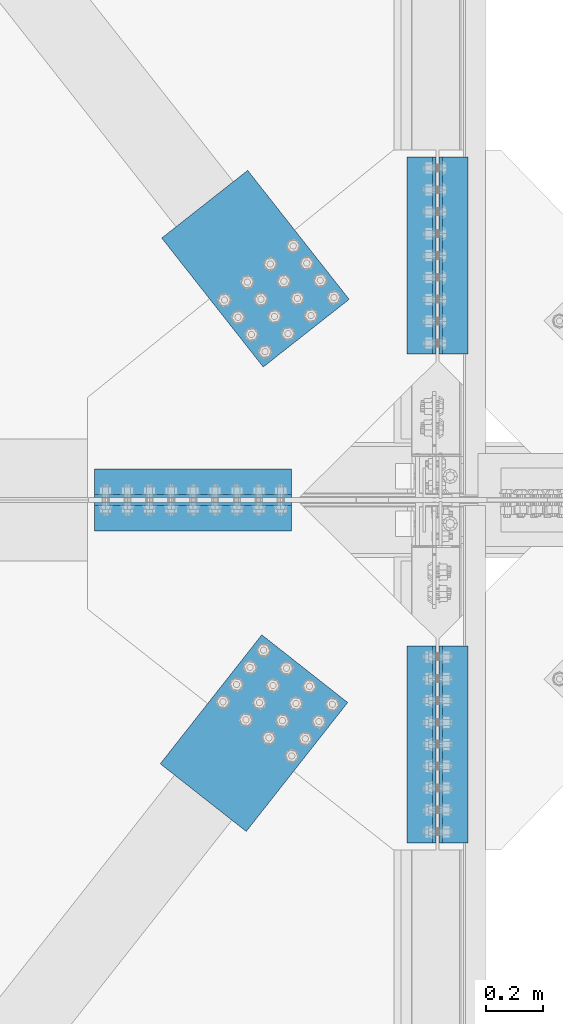
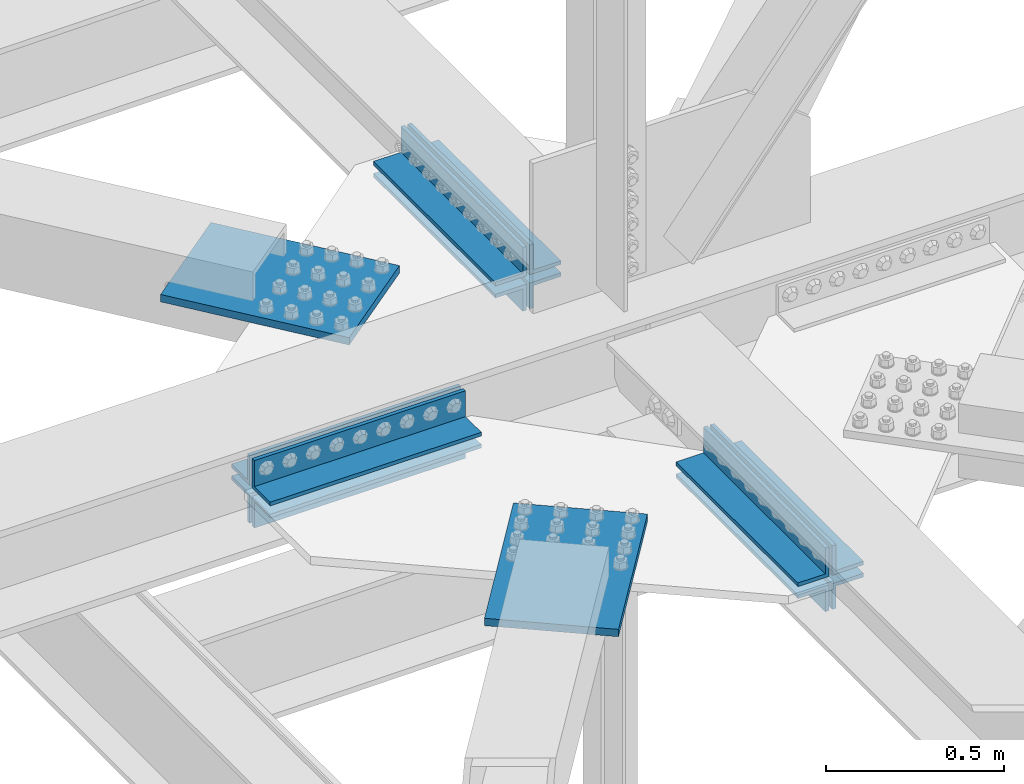
# One storey, part 2360 of 3843: 14 beams, 6 elements without a shape of their own.
"""IFC2X3 building model written with IfcOpenShell, lengths in millimetres."""

from ifc_helpers import new_model, si_unit, frame, origin_with_axes, place, context, subcontext, project, spatial, faceted_brep, material, type_object, element, aggregate, save


model = new_model("IFC2X3")

# Units and contexts
model_context = context("Model", 3, precision=1e-05, world=origin_with_axes())
body_context = subcontext(model_context, "Body", "Model", "MODEL_VIEW")
ifc_project = project(units=[si_unit("LENGTHUNIT", "METRE", prefix="MILLI"), si_unit("AREAUNIT", "SQUARE_METRE"), si_unit("VOLUMEUNIT", "CUBIC_METRE"), si_unit("MASSUNIT", "GRAM", prefix="KILO"), si_unit("TIMEUNIT", "SECOND"), si_unit("PLANEANGLEUNIT", "RADIAN"), si_unit("SOLIDANGLEUNIT", "STERADIAN"), si_unit("THERMODYNAMICTEMPERATUREUNIT", "DEGREE_CELSIUS"), si_unit("LUMINOUSINTENSITYUNIT", "LUMEN")], contexts=[model_context])

# Site, building, storey
site_placement = place(None, origin_with_axes())
site = spatial("IfcSite", under=ifc_project, at=site_placement, CompositionType="ELEMENT")
building_placement = place(site_placement, origin_with_axes())
building = spatial("IfcBuilding", under=site, at=building_placement, Name="Undefined", CompositionType="ELEMENT")
storey_placement = place(building_placement, origin_with_axes())
storey = spatial("IfcBuildingStorey", under=building, at=storey_placement, Name="Undefined", CompositionType="ELEMENT", Elevation=0.0)

# Assembly, beam
assembly_1_placement = place(storey_placement, origin_with_axes())
assembly_1 = element("IfcElementAssembly", 1, at=assembly_1_placement, inside=storey, Name="PLATE", AssemblyPlace="NOTDEFINED", PredefinedType="RIGID_FRAME")
ifc_material = material(Name="STEEL/A572-50")
beam_type_1 = type_object("IfcBeamType", Name="L4X4X1/2", PredefinedType="NOTDEFINED")
beam_1_placement = place(assembly_1_placement, frame((76504.8000192098, 58973.2439848795, 42167.1749999991), z_axis=(0.0, 1.0, 0.0), x_axis=(-1.0, 0.0, 0.0)))
beam_1 = element("IfcBeam", 2, at=beam_1_placement, type_object=beam_type_1, material=ifc_material, Name="ANGLE", ObjectType="L4X4X1/2", context=body_context, shape_type="Brep", body=[
    faceted_brep([(0.0, 50.8000000000029, -50.8000000000029), (0.0, 50.8000000000029, 50.8000000000029), (685.800000000003, 50.8000000000029, 50.8000000000029), (685.800000000003, 50.8000000000029, -50.8000000000029), (0.0, 38.0999999999985, 50.8000000000029), (685.800000000003, 38.0999999999985, 50.8000000000029), (0.0, 38.0999999999985, -38.0999999999985), (685.800000000003, 38.0999999999985, -38.1000000000058), (0.0, -50.8000000000029, -38.1000000000058), (685.800000000003, -50.8000000000029, -38.1000000000058), (0.0, -50.8000000000029, -50.8000000000029), (685.800000000003, -50.8000000000029, -50.8000000000029)], [[[0, 1, 2, 3]], [[1, 4, 5, 2]], [[4, 6, 7, 5]], [[6, 8, 9, 7]], [[8, 10, 11, 9]], [[10, 0, 3, 11]], [[5, 7, 9, 11, 3, 2]], [[10, 8, 6, 4, 1, 0]]]),
])

assembly_2_placement = place(storey_placement, origin_with_axes())
assembly_2 = element("IfcElementAssembly", 3, at=assembly_2_placement, inside=storey, Name="PLATE", AssemblyPlace="NOTDEFINED", PredefinedType="RIGID_FRAME")
beam_2_placement = place(assembly_2_placement, frame((75819.0000192098, 58857.356234873, 42167.1744995137), z_axis=(0.0, -1.0, 0.0), x_axis=(1.0, 0.0, 0.0)))
beam_2 = element("IfcBeam", 4, at=beam_2_placement, type_object=beam_type_1, material=ifc_material, Name="ANGLE", ObjectType="L4X4X1/2", context=body_context, shape_type="Brep", body=[
    faceted_brep([(0.0, 50.8000000000029, -50.8000000000029), (0.0, 50.8000000000029, 50.8000000000029), (685.800000000003, 50.8000000000029, 50.8000000000029), (685.800000000003, 50.8000000000029, -50.8000000000029), (0.0, 38.0999999999985, 50.8000000000029), (685.800000000003, 38.0999999999985, 50.8000000000029), (0.0, 38.0999999999985, -38.0999999999985), (685.800000000003, 38.0999999999985, -38.1000000000058), (0.0, -50.8000000000029, -38.1000000000058), (685.800000000003, -50.8000000000029, -38.1000000000058), (0.0, -50.8000000000029, -50.8000000000029), (685.800000000003, -50.8000000000029, -50.8000000000029)], [[[0, 1, 2, 3]], [[1, 4, 5, 2]], [[4, 6, 7, 5]], [[6, 8, 9, 7]], [[8, 10, 11, 9]], [[10, 0, 3, 11]], [[5, 7, 9, 11, 3, 2]], [[10, 8, 6, 4, 1, 0]]]),
])

assembly_3_placement = place(storey_placement, origin_with_axes())
assembly_3 = element("IfcElementAssembly", 5, at=assembly_3_placement, inside=storey, Name="PLATE", AssemblyPlace="NOTDEFINED", PredefinedType="RIGID_FRAME")
beam_3_placement = place(assembly_3_placement, frame((77068.3625222877, 60109.0999848818, 42297.3495002747), z_axis=(1.0, 0.0, 0.0), x_axis=(0.0, -1.0, 0.0)))
beam_3 = element("IfcBeam", 6, at=beam_3_placement, type_object=beam_type_1, material=ifc_material, Name="ANGLE", ObjectType="L4X4X1/2", context=body_context, shape_type="Brep", body=[
    faceted_brep([(0.0, 50.8000000000029, -50.8000000000029), (0.0, 50.8000000000029, 50.8000000000029), (685.800000000003, 50.8000000000029, 50.8000000000029), (685.800000000003, 50.8000000000029, -50.8000000000029), (0.0, 38.0999999999985, 50.8000000000029), (685.800000000003, 38.0999999999985, 50.8000000000029), (0.0, 38.0999999999985, -38.0999999999985), (685.800000000003, 38.0999999999985, -38.1000000000058), (0.0, -50.8000000000029, -38.1000000000058), (685.800000000003, -50.8000000000029, -38.1000000000058), (0.0, -50.8000000000029, -50.8000000000029), (685.800000000003, -50.8000000000029, -50.8000000000029)], [[[0, 1, 2, 3]], [[1, 4, 5, 2]], [[4, 6, 7, 5]], [[6, 8, 9, 7]], [[8, 10, 11, 9]], [[10, 0, 3, 11]], [[5, 7, 9, 11, 3, 2]], [[10, 8, 6, 4, 1, 0]]]),
])

assembly_4_placement = place(storey_placement, origin_with_axes())
assembly_4 = element("IfcElementAssembly", 7, at=assembly_4_placement, inside=storey, Name="PLATE", AssemblyPlace="NOTDEFINED", PredefinedType="RIGID_FRAME")
beam_4_placement = place(assembly_4_placement, frame((77068.362519207, 58407.2999848772, 42297.3495002747), z_axis=(1.0, 0.0, 0.0), x_axis=(0.0, -1.0, 0.0)))
beam_4 = element("IfcBeam", 8, at=beam_4_placement, type_object=beam_type_1, material=ifc_material, Name="ANGLE", ObjectType="L4X4X1/2", context=body_context, shape_type="Brep", body=[
    faceted_brep([(0.0, 50.8000000000029, -50.8000000000029), (0.0, 50.8000000000029, 50.8000000000029), (685.800000000003, 50.8000000000029, 50.8000000000029), (685.800000000003, 50.8000000000029, -50.8000000000029), (0.0, 38.0999999999985, 50.8000000000029), (685.800000000003, 38.0999999999985, 50.8000000000029), (0.0, 38.0999999999985, -38.0999999999985), (685.800000000003, 38.0999999999985, -38.1000000000058), (0.0, -50.8000000000029, -38.1000000000058), (685.800000000003, -50.8000000000029, -38.1000000000058), (0.0, -50.8000000000029, -50.8000000000029), (685.800000000003, -50.8000000000029, -50.8000000000029)], [[[0, 1, 2, 3]], [[1, 4, 5, 2]], [[4, 6, 7, 5]], [[6, 8, 9, 7]], [[8, 10, 11, 9]], [[10, 0, 3, 11]], [[5, 7, 9, 11, 3, 2]], [[10, 8, 6, 4, 1, 0]]]),
])

# Beam
beam_5_placement = place(assembly_1_placement, frame((75819.000019208, 58973.2437348795, 42297.3495002747), z_axis=(0.0, 1.0, 0.0), x_axis=(1.0, 0.0, 0.0)))
beam_5 = element("IfcBeam", 9, at=beam_5_placement, type_object=beam_type_1, material=ifc_material, Name="ANGLE", ObjectType="L4X4X1/2", context=body_context, shape_type="Brep", body=[
    faceted_brep([(0.0, 50.8000000000029, -50.8000000000029), (0.0, 50.8000000000029, 50.8000000000029), (685.800000000003, 50.8000000000029, 50.8000000000029), (685.800000000003, 50.8000000000029, -50.8000000000029), (0.0, 38.0999999999985, 50.8000000000029), (685.800000000003, 38.0999999999985, 50.8000000000029), (0.0, 38.0999999999985, -38.0999999999985), (685.800000000003, 38.0999999999985, -38.1000000000058), (0.0, -50.8000000000029, -38.1000000000058), (685.800000000003, -50.8000000000029, -38.1000000000058), (0.0, -50.8000000000029, -50.8000000000029), (685.800000000003, -50.8000000000029, -50.8000000000029)], [[[0, 1, 2, 3]], [[1, 4, 5, 2]], [[4, 6, 7, 5]], [[6, 8, 9, 7]], [[8, 10, 11, 9]], [[10, 0, 3, 11]], [[5, 7, 9, 11, 3, 2]], [[10, 8, 6, 4, 1, 0]]]),
])

beam_6_placement = place(assembly_1_placement, frame((76957.2375222877, 59423.2999848818, 42297.3495002747), z_axis=(-1.0, 0.0, 0.0), x_axis=(0.0, 1.0, 0.0)))
beam_6 = element("IfcBeam", 10, at=beam_6_placement, type_object=beam_type_1, material=ifc_material, Name="ANGLE", ObjectType="L4X4X1/2", context=body_context, shape_type="Brep", body=[
    faceted_brep([(0.0, 50.8000000000029, -50.8000000000029), (0.0, 50.8000000000029, 50.8000000000029), (685.800000000003, 50.8000000000029, 50.8000000000029), (685.800000000003, 50.8000000000029, -50.8000000000029), (0.0, 38.0999999999985, 50.8000000000029), (685.800000000003, 38.0999999999985, 50.8000000000029), (0.0, 38.0999999999985, -38.0999999999985), (685.800000000003, 38.0999999999985, -38.1000000000058), (0.0, -50.8000000000029, -38.1000000000058), (685.800000000003, -50.8000000000029, -38.1000000000058), (0.0, -50.8000000000029, -50.8000000000029), (685.800000000003, -50.8000000000029, -50.8000000000029)], [[[0, 1, 2, 3]], [[1, 4, 5, 2]], [[4, 6, 7, 5]], [[6, 8, 9, 7]], [[8, 10, 11, 9]], [[10, 0, 3, 11]], [[5, 7, 9, 11, 3, 2]], [[10, 8, 6, 4, 1, 0]]]),
])

beam_7_placement = place(assembly_2_placement, frame((76504.800019208, 58857.3562348795, 42297.3495002747), z_axis=(0.0, -1.0, 0.0), x_axis=(-1.0, 0.0, 0.0)))
beam_7 = element("IfcBeam", 11, at=beam_7_placement, type_object=beam_type_1, material=ifc_material, Name="ANGLE", ObjectType="L4X4X1/2", context=body_context, shape_type="Brep", body=[
    faceted_brep([(0.0, 50.8000000000029, -50.8000000000029), (0.0, 50.8000000000029, 50.8000000000029), (685.800000000003, 50.8000000000029, 50.8000000000029), (685.800000000003, 50.8000000000029, -50.8000000000029), (0.0, 38.0999999999985, 50.8000000000029), (685.800000000003, 38.0999999999985, 50.8000000000029), (0.0, 38.0999999999985, -38.0999999999985), (685.800000000003, 38.0999999999985, -38.1000000000058), (0.0, -50.8000000000029, -38.1000000000058), (685.800000000003, -50.8000000000029, -38.1000000000058), (0.0, -50.8000000000029, -50.8000000000029), (685.800000000003, -50.8000000000029, -50.8000000000029)], [[[0, 1, 2, 3]], [[1, 4, 5, 2]], [[4, 6, 7, 5]], [[6, 8, 9, 7]], [[8, 10, 11, 9]], [[10, 0, 3, 11]], [[5, 7, 9, 11, 3, 2]], [[10, 8, 6, 4, 1, 0]]]),
])

beam_8_placement = place(assembly_2_placement, frame((76957.237519207, 57721.4999848772, 42297.3495002747), z_axis=(-1.0, 0.0, 0.0), x_axis=(0.0, 1.0, 0.0)))
beam_8 = element("IfcBeam", 12, at=beam_8_placement, type_object=beam_type_1, material=ifc_material, Name="ANGLE", ObjectType="L4X4X1/2", context=body_context, shape_type="Brep", body=[
    faceted_brep([(0.0, 50.8000000000029, -50.8000000000029), (0.0, 50.8000000000029, 50.8000000000029), (685.800000000003, 50.8000000000029, 50.8000000000029), (685.800000000003, 50.8000000000029, -50.8000000000029), (0.0, 38.0999999999985, 50.8000000000029), (685.800000000003, 38.0999999999985, 50.8000000000029), (0.0, 38.0999999999985, -38.0999999999985), (685.800000000003, 38.0999999999985, -38.1000000000058), (0.0, -50.8000000000029, -38.1000000000058), (685.800000000003, -50.8000000000029, -38.1000000000058), (0.0, -50.8000000000029, -50.8000000000029), (685.800000000003, -50.8000000000029, -50.8000000000029)], [[[0, 1, 2, 3]], [[1, 4, 5, 2]], [[4, 6, 7, 5]], [[6, 8, 9, 7]], [[8, 10, 11, 9]], [[10, 0, 3, 11]], [[5, 7, 9, 11, 3, 2]], [[10, 8, 6, 4, 1, 0]]]),
])

beam_type_2 = type_object("IfcBeamType", Name="L4X3-1/2X1/2", PredefinedType="NOTDEFINED")
beam_9_placement = place(assembly_3_placement, frame((77068.3625222877, 59423.2999848818, 42173.5244995117), z_axis=(1.0, 0.0, 0.0), x_axis=(0.0, 1.0, 0.0)))
beam_9 = element("IfcBeam", 13, at=beam_9_placement, type_object=beam_type_2, material=ifc_material, Name="ANGLE", ObjectType="L4X3-1/2X1/2", context=body_context, shape_type="Brep", body=[
    faceted_brep([(0.0, 44.4499999999971, -50.8000000000029), (0.0, 44.4499999999971, 50.8000000000029), (685.800000000003, 44.4499999999971, 50.8000000000029), (685.800000000003, 44.4499999999971, -50.8000000000029), (0.0, 31.75, 50.8000000000029), (685.800000000003, 31.75, 50.8000000000029), (0.0, 31.7500000838336, -38.0999999999985), (685.800000000003, 31.75, -38.0999999999985), (4.36557456851006e-11, -44.4500000000226, -38.0999999999985), (685.800000000003, -44.4499999999971, -38.0999999999985), (0.0, -44.4499999999971, -50.8000000000029), (685.800000000003, -44.4499999999971, -50.8000000000029)], [[[0, 1, 2, 3]], [[1, 4, 5, 2]], [[4, 6, 7, 5]], [[6, 8, 9, 7]], [[8, 10, 11, 9]], [[10, 0, 3, 11]], [[5, 7, 9, 11, 3, 2]], [[10, 8, 6, 4, 1, 0]]]),
])

aggregate(assembly_3, [beam_9, beam_3])

beam_10_placement = place(assembly_1_placement, frame((76957.2375222877, 60109.0999848817, 42173.5244979858), z_axis=(-1.0, 0.0, 0.0), x_axis=(0.0, -1.0, 0.0)))
beam_10 = element("IfcBeam", 14, at=beam_10_placement, type_object=beam_type_2, material=ifc_material, Name="ANGLE", ObjectType="L4X3-1/2X1/2", context=body_context, shape_type="Brep", body=[
    faceted_brep([(0.0, 44.4499999999971, -50.8000000000029), (0.0, 44.4499999999971, 50.8000000000029), (685.800000000003, 44.4499999999971, 50.8000000000029), (685.800000000003, 44.4499999999971, -50.8000000000029), (0.0, 31.75, 50.8000000000029), (685.800000000003, 31.75, 50.8000000000029), (0.0, 31.7500000838336, -38.0999999999985), (685.800000000003, 31.75, -38.0999999999985), (4.36557456851006e-11, -44.4500000000226, -38.0999999999985), (685.800000000003, -44.4499999999971, -38.0999999999985), (0.0, -44.4499999999971, -50.8000000000029), (685.800000000003, -44.4499999999971, -50.8000000000029)], [[[0, 1, 2, 3]], [[1, 4, 5, 2]], [[4, 6, 7, 5]], [[6, 8, 9, 7]], [[8, 10, 11, 9]], [[10, 0, 3, 11]], [[5, 7, 9, 11, 3, 2]], [[10, 8, 6, 4, 1, 0]]]),
])

aggregate(assembly_1, [beam_10, beam_1, beam_5, beam_6])

beam_11_placement = place(assembly_2_placement, frame((76957.2375192069, 58407.2999848772, 42173.5244979858), z_axis=(-1.0, 0.0, 0.0), x_axis=(0.0, -1.0, 0.0)))
beam_11 = element("IfcBeam", 15, at=beam_11_placement, type_object=beam_type_2, material=ifc_material, Name="ANGLE", ObjectType="L4X3-1/2X1/2", context=body_context, shape_type="Brep", body=[
    faceted_brep([(0.0, 44.4499999999971, -50.8000000000029), (0.0, 44.4499999999971, 50.8000000000029), (685.800000000003, 44.4499999999971, 50.8000000000029), (685.800000000003, 44.4499999999971, -50.8000000000029), (0.0, 31.75, 50.8000000000029), (685.800000000003, 31.75, 50.8000000000029), (0.0, 31.7500000838336, -38.0999999999985), (685.800000000003, 31.75, -38.0999999999985), (4.36557456851006e-11, -44.4500000000226, -38.0999999999985), (685.800000000003, -44.4499999999971, -38.0999999999985), (0.0, -44.4499999999971, -50.8000000000029), (685.800000000003, -44.4499999999971, -50.8000000000029)], [[[0, 1, 2, 3]], [[1, 4, 5, 2]], [[4, 6, 7, 5]], [[6, 8, 9, 7]], [[8, 10, 11, 9]], [[10, 0, 3, 11]], [[5, 7, 9, 11, 3, 2]], [[10, 8, 6, 4, 1, 0]]]),
])

aggregate(assembly_2, [beam_11, beam_2, beam_7, beam_8])

beam_12_placement = place(assembly_4_placement, frame((77068.3625192069, 57721.4999848772, 42173.5244995117), z_axis=(1.0, 0.0, 0.0), x_axis=(0.0, 1.0, 0.0)))
beam_12 = element("IfcBeam", 16, at=beam_12_placement, type_object=beam_type_2, material=ifc_material, Name="ANGLE", ObjectType="L4X3-1/2X1/2", context=body_context, shape_type="Brep", body=[
    faceted_brep([(0.0, 44.4499999999971, -50.8000000000029), (0.0, 44.4499999999971, 50.8000000000029), (685.800000000003, 44.4499999999971, 50.8000000000029), (685.800000000003, 44.4499999999971, -50.8000000000029), (0.0, 31.75, 50.8000000000029), (685.800000000003, 31.75, 50.8000000000029), (0.0, 31.7500000838336, -38.0999999999985), (685.800000000003, 31.75, -38.0999999999985), (4.36557456851006e-11, -44.4500000000226, -38.0999999999985), (685.800000000003, -44.4499999999971, -38.0999999999985), (0.0, -44.4499999999971, -50.8000000000029), (685.800000000003, -44.4499999999971, -50.8000000000029)], [[[0, 1, 2, 3]], [[1, 4, 5, 2]], [[4, 6, 7, 5]], [[6, 8, 9, 7]], [[8, 10, 11, 9]], [[10, 0, 3, 11]], [[5, 7, 9, 11, 3, 2]], [[10, 8, 6, 4, 1, 0]]]),
])

aggregate(assembly_4, [beam_12, beam_4])

# Assembly, beam
assembly_5_placement = place(storey_placement, origin_with_axes())
assembly_5 = element("IfcElementAssembly", 17, at=assembly_5_placement, inside=storey, AssemblyPlace="NOTDEFINED", PredefinedType="RIGID_FRAME")
beam_type_3 = type_object("IfcBeamType", PredefinedType="NOTDEFINED")
beam_13_placement = place(assembly_5_placement, frame((76555.5655320163, 59496.1110299653, 42259.2489992142), z_axis=(0.785737876999385, 0.618559607999504, 0.0), x_axis=(-0.618559606896105, 0.785737877868018, 0.0)))
beam_13 = element("IfcBeam", 18, at=beam_13_placement, type_object=beam_type_3, material=ifc_material, Name="PLATE", context=body_context, shape_type="Brep", body=[
    faceted_brep([(5.85714587941766e-10, 12.6999999999971, -190.500000000349), (-6.14818418398499e-10, 12.6999999999971, 190.500000000364), (571.499999996191, 12.6999999999971, 190.49999999936), (571.499999997392, 12.6999999999971, -190.500000001353), (-6.14818418398499e-10, -12.6999999999971, 190.500000000364), (571.499999996191, -12.6999999999971, 190.49999999936), (5.85714587941766e-10, -12.6999999999971, -190.500000000349), (571.499999997392, -12.6999999999971, -190.500000001353)], [[[0, 1, 2, 3]], [[1, 4, 5, 2]], [[4, 6, 7, 5]], [[6, 0, 3, 7]], [[5, 7, 3, 2]], [[6, 4, 1, 0]]]),
])
aggregate(assembly_5, [beam_13])

assembly_6_placement = place(storey_placement, origin_with_axes())
assembly_6 = element("IfcElementAssembly", 19, at=assembly_6_placement, inside=storey, AssemblyPlace="NOTDEFINED", PredefinedType="RIGID_FRAME")
beam_14_placement = place(assembly_6_placement, frame((76550.4637538229, 58328.0079732248, 42259.2489992142), z_axis=(0.785737878354044, -0.61855960627872, 0.0), x_axis=(-0.618559605175322, -0.785737879222676, 0.0)))
beam_14 = element("IfcBeam", 20, at=beam_14_placement, type_object=beam_type_3, material=ifc_material, Name="PLATE", context=body_context, shape_type="Brep", body=[
    faceted_brep([(5.85714587941766e-10, 12.6999999999971, -190.500000000349), (-6.14818418398499e-10, 12.6999999999971, 190.500000000364), (571.499999996191, 12.6999999999971, 190.49999999936), (571.499999997392, 12.6999999999971, -190.500000001353), (-6.14818418398499e-10, -12.6999999999971, 190.500000000364), (571.499999996191, -12.6999999999971, 190.49999999936), (5.85714587941766e-10, -12.6999999999971, -190.500000000349), (571.499999997392, -12.6999999999971, -190.500000001353)], [[[0, 1, 2, 3]], [[1, 4, 5, 2]], [[4, 6, 7, 5]], [[6, 0, 3, 7]], [[5, 7, 3, 2]], [[6, 4, 1, 0]]]),
])
aggregate(assembly_6, [beam_14])

save(model, "model.ifc")
